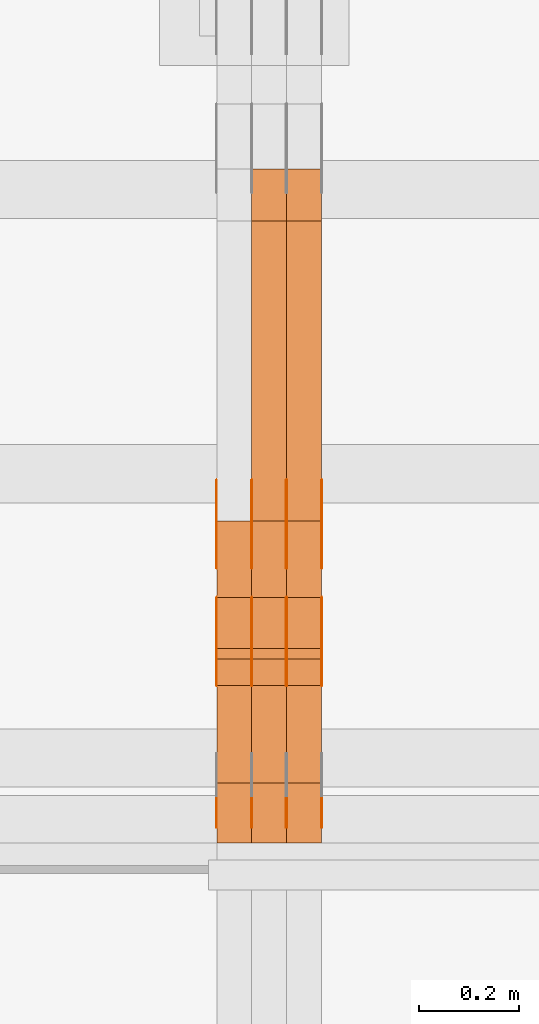
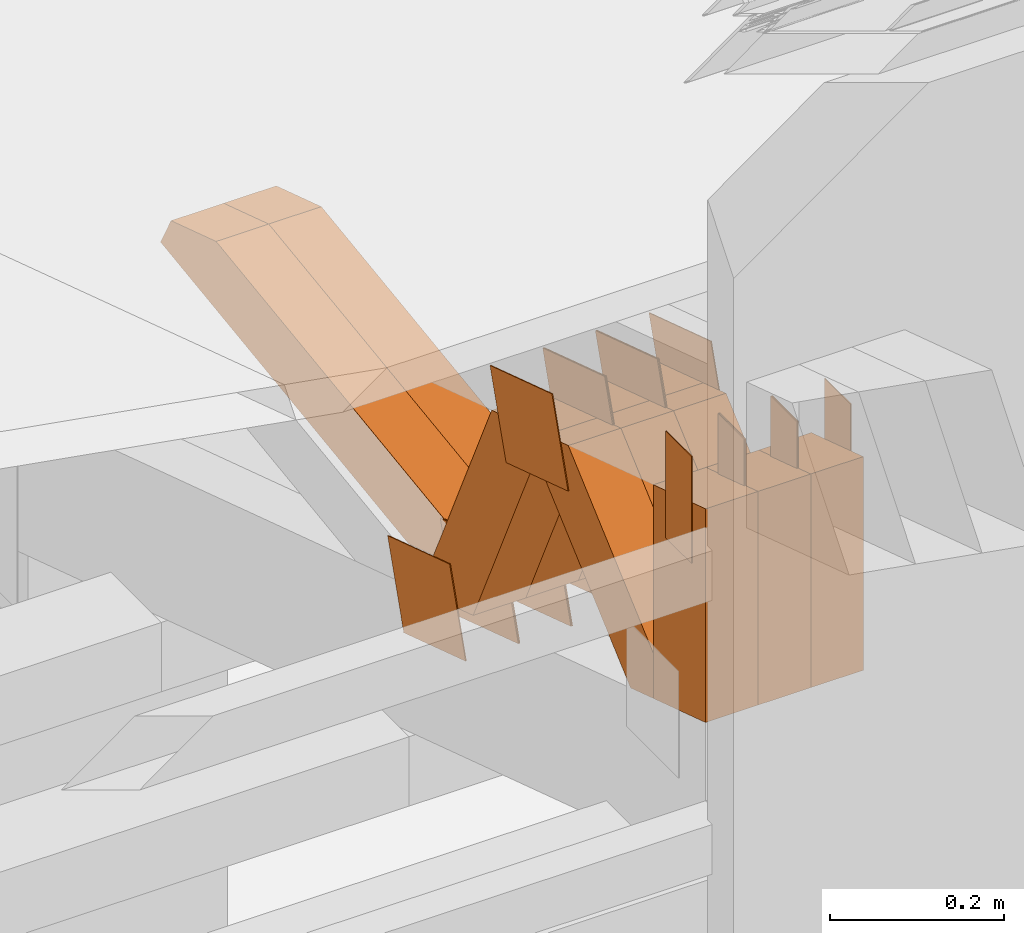
# One storey, part 102 of 385: 29 proxies.
"""IFC2X3 building model written with IfcOpenShell, lengths in millimetres."""

import ifcopenshell
import ifcopenshell.guid

model = None  # the IFC model being written
_history = None  # IfcOwnerHistory: only IFC2X3 demands one
_inside = {}  # id of a spatial element -> (the spatial element, [elements in it])
_under = {}  # id of a project, library or spatial element -> (it, [spatial elements below it])
_declared = {}  # id of a project -> (the project, [libraries it declares])
_typed = {}  # id of a type object -> (the type object, [elements of that type])
_made_of = {}  # id of a material, layer set ... -> (it, [elements and type objects made of it])


def new_model(schema):
    """Start an empty IFC model of exactly this schema.

    Asked for "IFC4X3", IfcOpenShell would pick the latest addendum, in which some entities
    have other attributes; the version numbers below select the first issue.
    IFC2X3 requires an IfcOwnerHistory on every rooted entity: one is made here for all.
    """
    global model, _history
    if schema == "IFC4X3":
        model = ifcopenshell.file(schema_version=(4, 3, 0, 0))
    else:
        model = ifcopenshell.file(schema=schema)
    _inside.clear()
    _under.clear()
    _declared.clear()
    _typed.clear()
    _made_of.clear()
    _history = None
    if model.schema == "IFC2X3":
        org = make("IfcOrganization", Name="unknown")
        user = make(
            "IfcPersonAndOrganization",
            ThePerson=make("IfcPerson", FamilyName="unknown"),
            TheOrganization=org,
        )
        app = make(
            "IfcApplication",
            ApplicationDeveloper=org,
            Version="unknown",
            ApplicationFullName="unknown",
            ApplicationIdentifier="unknown",
        )
        _history = make(
            "IfcOwnerHistory",
            OwningUser=user,
            OwningApplication=app,
            ChangeAction="ADDED",
            CreationDate=0,
        )
    return model


def make(cls, **values):
    """One entity of the class cls with the attributes given. An attribute that is None is left unset."""
    return model.create_entity(
        cls, **{name: value for name, value in values.items() if value is not None}
    )


def entity(cls, *values):
    """Any entity or typed value of the class cls, its attributes in the order of the schema. None: left unset."""
    e = model.create_entity(cls)
    for i, value in enumerate(values):
        if value is not None:
            e[i] = value
    return e


def rooted(cls, **values):
    """An entity with a GlobalId (a new one), such as an element, a storey or a relation."""
    return make(cls, GlobalId=ifcopenshell.guid.new(), OwnerHistory=_history, **values)


def si_unit(unit_type, name, prefix=None):
    """IfcSIUnit, for example si_unit("LENGTHUNIT", "METRE", prefix="MILLI")."""
    return make("IfcSIUnit", UnitType=unit_type, Prefix=prefix, Name=name)


def converted_unit(unit_type, name, factor, base, dimensions=None, offset=None):
    """IfcConversionBasedUnit, such as the inch: factor (a typed value) times the base unit."""
    return make(
        "IfcConversionBasedUnit"
        if offset is None
        else "IfcConversionBasedUnitWithOffset",
        ConversionOffset=offset,
        Dimensions=None
        if dimensions is None
        else entity("IfcDimensionalExponents", *dimensions),
        UnitType=unit_type,
        Name=name,
        ConversionFactor=make(
            "IfcMeasureWithUnit", ValueComponent=factor, UnitComponent=base
        ),
    )


def derived_unit(unit_type, elements):
    """IfcDerivedUnit: a product of units, each with its exponent."""
    return make(
        "IfcDerivedUnit",
        Elements=[
            make("IfcDerivedUnitElement", Unit=unit, Exponent=power)
            for unit, power in elements
        ],
        UnitType=unit_type,
    )


def assignment(units):
    """IfcUnitAssignment: the units of a project."""
    return None if units is None else make("IfcUnitAssignment", Units=units)


def point(xyz):
    """IfcCartesianPoint."""
    return None if xyz is None else make("IfcCartesianPoint", Coordinates=xyz)


def direction(xyz):
    """IfcDirection."""
    return None if xyz is None else make("IfcDirection", DirectionRatios=xyz)


def frame(location, z_axis=None, x_axis=None):
    """IfcAxis2Placement3D, a coordinate frame: its origin and axes. An axis left out is left unset."""
    return make(
        "IfcAxis2Placement3D",
        Location=point(location),
        Axis=direction(z_axis),
        RefDirection=direction(x_axis),
    )


def frame_2d(location, x_axis=None):
    """IfcAxis2Placement2D, a coordinate frame in the plane: its origin and x axis."""
    return make(
        "IfcAxis2Placement2D", Location=point(location), RefDirection=direction(x_axis)
    )


def origin():
    """The frame at (0, 0, 0) with its axes left unset."""
    return frame((0.0, 0.0, 0.0))


def origin_2d_with_axis():
    """The frame at (0, 0) in the plane with the x axis (1, 0) written out."""
    return frame_2d((0.0, 0.0), x_axis=(1.0, 0.0))


def place(relative_to, where):
    """IfcLocalPlacement: puts the frame where relative to a parent placement (None: the world)."""
    return make(
        "IfcLocalPlacement", PlacementRelTo=relative_to, RelativePlacement=where
    )


def context(
    kind, dimensions, precision=None, world=None, true_north=None, identifier=None
):
    """IfcGeometricRepresentationContext, for example the 3D "Model" context."""
    return make(
        "IfcGeometricRepresentationContext",
        ContextIdentifier=identifier,
        ContextType=kind,
        CoordinateSpaceDimension=dimensions,
        Precision=precision,
        WorldCoordinateSystem=world,
        TrueNorth=true_north,
    )


def subcontext(parent, identifier, kind, view, scale=None):
    """IfcGeometricRepresentationSubContext, for example "Body" below "Model"."""
    return make(
        "IfcGeometricRepresentationSubContext",
        ContextIdentifier=identifier,
        ContextType=kind,
        ParentContext=parent,
        TargetScale=scale,
        TargetView=view,
    )


def project(units=None, contexts=None):
    """IfcProject with its units and contexts."""
    return rooted(
        "IfcProject",
        Name="project",
        RepresentationContexts=contexts,
        UnitsInContext=assignment(units),
    )


def spatial(cls, under=None, at=None, **own):
    """A site, building, storey or space (cls), placed at a placement, below another one or the project."""
    s = rooted(cls, ObjectPlacement=at, **own)
    if under is not None:
        _under.setdefault(under.id(), (under, []))[1].append(s)
    return s


def polyline(points):
    """IfcPolyline through the points."""
    return make("IfcPolyline", Points=[point(p) for p in points])


def profile(cls, at=None, kind="AREA", **sizes):
    """A parametric profile (cls). Its sizes go by their IFC names, for example OverallWidth=200.0."""
    return make(cls, ProfileType=kind, Position=at, **sizes)


def rectangle(**sizes):
    """IfcRectangleProfileDef."""
    return profile("IfcRectangleProfileDef", **sizes)


def outline(outer, holes=None, kind="AREA"):
    """IfcArbitraryClosedProfileDef: a profile drawn as a closed curve; with holes, ...WithVoids."""
    if holes is None:
        return make("IfcArbitraryClosedProfileDef", ProfileType=kind, OuterCurve=outer)
    return make(
        "IfcArbitraryProfileDefWithVoids",
        ProfileType=kind,
        OuterCurve=outer,
        InnerCurves=holes,
    )


def extrude(swept, where, along, depth):
    """IfcExtrudedAreaSolid: the profile swept, set in the frame where, extruded along a direction by depth."""
    return make(
        "IfcExtrudedAreaSolid",
        SweptArea=swept,
        Position=where,
        ExtrudedDirection=direction(along),
        Depth=depth,
    )


def shape(context_of_items, identifier, shape_type, items):
    """IfcShapeRepresentation: the items that make up one representation, for example the "Body"."""
    return make(
        "IfcShapeRepresentation",
        ContextOfItems=context_of_items,
        RepresentationIdentifier=identifier,
        RepresentationType=shape_type,
        Items=items,
    )


def source(mapping_origin, context_of_items, identifier, shape_type, items):
    """IfcRepresentationMap: a shape defined once, which mapped items show again and again."""
    return make(
        "IfcRepresentationMap",
        MappingOrigin=mapping_origin,
        MappedRepresentation=shape(context_of_items, identifier, shape_type, items),
    )


def transform(
    local_origin,
    x_axis=None,
    y_axis=None,
    z_axis=None,
    scale=None,
    scale2=None,
    scale3=None,
    uniform=True,
):
    """IfcCartesianTransformationOperator3D, or its non-uniform kind. x_axis, y_axis, z_axis: its Axis1, 2, 3."""
    if uniform:
        return make(
            "IfcCartesianTransformationOperator3D",
            Axis1=direction(x_axis),
            Axis2=direction(y_axis),
            LocalOrigin=point(local_origin),
            Scale=scale,
            Axis3=direction(z_axis),
        )
    return make(
        "IfcCartesianTransformationOperator3DnonUniform",
        Axis1=direction(x_axis),
        Axis2=direction(y_axis),
        LocalOrigin=point(local_origin),
        Scale=scale,
        Axis3=direction(z_axis),
        Scale2=scale2,
        Scale3=scale3,
    )


def mapped(mapping_source, mapping_target):
    """IfcMappedItem: shows the shape of a source again, moved by a transform."""
    return make(
        "IfcMappedItem", MappingSource=mapping_source, MappingTarget=mapping_target
    )


def material(Name=None, Category=None):
    """IfcMaterial."""
    return make("IfcMaterial", Name=Name, Category=Category)


def made_of(thing, what):
    """Note that an element or type object is made of a material, layer set ...; save() writes the relation."""
    if what is not None:
        _made_of.setdefault(what.id(), (what, []))[1].append(thing)
    return thing


def type_object(cls, material=None, **own):
    """A type object (cls), such as IfcWallType, which elements share."""
    return made_of(rooted(cls, **own), material)


def type_shapes(of_type, sources):
    """Give a type object the sources (RepresentationMaps) that its elements show as mapped items."""
    of_type.RepresentationMaps = sources


def element(
    cls,
    number,
    at=None,
    inside=None,
    cuts=None,
    type_object=None,
    material=None,
    context=None,
    identifier="Body",
    shape_type=None,
    held_by="IfcProductDefinitionShape",
    body=None,
    shapes=None,
    **own,
):
    """One element of the class cls, such as IfcWall. Its Tag is "e" and its number.

    at: its placement. inside: the storey or other place that contains it. cuts: it is an
    opening in that element (IfcRelVoidsElement). A single representation is given by context,
    identifier, shape_type and body (its items); several are given by shapes. held_by: the class
    of the entity that holds the representations. save() writes the other relations.
    """
    e = rooted(cls, Tag="e%d" % number, ObjectPlacement=at, **own)
    if body is not None:
        shapes = [shape(context, identifier, shape_type, body)]
    if shapes is not None:
        e.Representation = make(held_by, Representations=shapes)
    if inside is not None:
        _inside.setdefault(inside.id(), (inside, []))[1].append(e)
    if cuts is not None:
        rooted(
            "IfcRelVoidsElement", RelatingBuildingElement=cuts, RelatedOpeningElement=e
        )
    if type_object is not None:
        _typed.setdefault(type_object.id(), (type_object, []))[1].append(e)
    return made_of(e, material)


def aggregate(whole, parts):
    """IfcRelAggregates: a whole, such as a stair, and the parts it consists of."""
    return rooted("IfcRelAggregates", RelatingObject=whole, RelatedObjects=parts)


def save(model, path):
    """Write the relations noted so far, then the file.

    IfcRelAggregates (storeys below a building ...), IfcRelContainedInSpatialStructure (elements
    in a storey), IfcRelDefinesByType, IfcRelAssociatesMaterial and IfcRelDeclares: one each for
    every whole, place, type object, material and project.
    """
    for whole, parts in _under.values():
        aggregate(whole, parts)
    for where, things in _inside.values():
        rooted(
            "IfcRelContainedInSpatialStructure",
            RelatedElements=things,
            RelatingStructure=where,
        )
    for kind, things in _typed.values():
        rooted("IfcRelDefinesByType", RelatedObjects=things, RelatingType=kind)
    for what, things in _made_of.values():
        rooted("IfcRelAssociatesMaterial", RelatedObjects=things, RelatingMaterial=what)
    for by, libraries in _declared.values():
        rooted("IfcRelDeclares", RelatingContext=by, RelatedDefinitions=libraries)
    model.write(path)


model = new_model("IFC2X3")

# Units and contexts
model_context = context("Model", 3, precision=0.01, world=origin(), true_north=direction((6.12303176911189e-17, 1.0)))
body_context = subcontext(model_context, "Body", "Model", "MODEL_VIEW")
ifc_project = project(units=[si_unit("LENGTHUNIT", "METRE", prefix="MILLI"), si_unit("AREAUNIT", "SQUARE_METRE"), si_unit("VOLUMEUNIT", "CUBIC_METRE"), converted_unit("PLANEANGLEUNIT", "DEGREE", entity("IfcRatioMeasure", 0.0174532925199433), si_unit("PLANEANGLEUNIT", "RADIAN"), dimensions=[0, 0, 0, 0, 0, 0, 0]), si_unit("MASSUNIT", "GRAM", prefix="KILO"), derived_unit("MASSDENSITYUNIT", [(si_unit("MASSUNIT", "GRAM", prefix="KILO"), 1), (si_unit("LENGTHUNIT", "METRE"), -3)]), si_unit("TIMEUNIT", "SECOND"), si_unit("FREQUENCYUNIT", "HERTZ"), si_unit("THERMODYNAMICTEMPERATUREUNIT", "DEGREE_CELSIUS"), derived_unit("THERMALTRANSMITTANCEUNIT", [(si_unit("MASSUNIT", "GRAM", prefix="KILO"), 1), (si_unit("THERMODYNAMICTEMPERATUREUNIT", "KELVIN"), -1), (si_unit("TIMEUNIT", "SECOND"), -3)]), derived_unit("VOLUMETRICFLOWRATEUNIT", [(si_unit("LENGTHUNIT", "METRE"), 3), (si_unit("TIMEUNIT", "SECOND"), -1)]), si_unit("ELECTRICCURRENTUNIT", "AMPERE"), si_unit("ELECTRICVOLTAGEUNIT", "VOLT"), si_unit("POWERUNIT", "WATT"), si_unit("FORCEUNIT", "NEWTON", prefix="KILO"), si_unit("ILLUMINANCEUNIT", "LUX"), si_unit("LUMINOUSFLUXUNIT", "LUMEN"), si_unit("LUMINOUSINTENSITYUNIT", "CANDELA"), derived_unit("USERDEFINED", [(si_unit("MASSUNIT", "GRAM", prefix="KILO"), -1), (si_unit("LENGTHUNIT", "METRE"), -2), (si_unit("TIMEUNIT", "SECOND"), 3), (si_unit("LUMINOUSFLUXUNIT", "LUMEN"), 1)]), derived_unit("LINEARVELOCITYUNIT", [(si_unit("LENGTHUNIT", "METRE"), 1), (si_unit("TIMEUNIT", "SECOND"), -1)]), si_unit("PRESSUREUNIT", "PASCAL"), derived_unit("USERDEFINED", [(si_unit("LENGTHUNIT", "METRE"), -2), (si_unit("MASSUNIT", "GRAM", prefix="KILO"), 1), (si_unit("TIMEUNIT", "SECOND"), -2)])], contexts=[model_context])

# Site, building, storey
site_placement = place(None, origin())
site = spatial("IfcSite", under=ifc_project, at=site_placement, CompositionType="ELEMENT")
building_placement = place(site_placement, origin())
building = spatial("IfcBuilding", under=site, at=building_placement, CompositionType="ELEMENT")
storey_placement = place(building_placement, origin())
storey = spatial("IfcBuildingStorey", under=building, at=storey_placement, Name="Default", CompositionType="ELEMENT", Elevation=0.0)

# Proxies
ifc_material_1 = material(Name="IfcSurfaceStyle #170604")
building_element_proxy_type_1 = type_object("IfcBuildingElementProxyType", PredefinedType="NOTDEFINED", material=ifc_material_1)
shared_shape_1 = source(origin(), body_context, "Body", "SweptSolid", [
    extrude(outline(polyline([(-74.9998605591118, -59.9999264677601), (74.9998754286171, -59.9999264677601), (74.9998605591118, 59.9999264677602), (-74.9998754286171, 59.9999264677602), (-74.9998605591118, -59.9999264677601)])), frame((74.9998754286171, 60.0000503992849, 0.0), z_axis=(0.0, 0.0, 1.0), x_axis=(-1.0, 0.0, 0.0)), (0.0, 0.0, 1.0), 1.3),
])
type_shapes(building_element_proxy_type_1, [shared_shape_1])
proxy_1_placement = place(building_placement, frame((12386.3, 16352.8320303235, 3323.23212676408), z_axis=(-1.0, 0.0, 0.0), x_axis=(0.0, -0.951056516295124, 0.309016994375039)))
element("IfcBuildingElementProxy", 1, at=proxy_1_placement, inside=storey, type_object=building_element_proxy_type_1, material=ifc_material_1, context=body_context, shape_type="MappedRepresentation", body=[
    mapped(shared_shape_1, transform((0.0, 0.0, 0.0), scale=1.0)),
])
ifc_material_2 = material(Name="IfcSurfaceStyle #170547")
building_element_proxy_type_2 = type_object("IfcBuildingElementProxyType", PredefinedType="NOTDEFINED", material=ifc_material_2)
shared_shape_2 = source(origin(), body_context, "Body", "SweptSolid", [
    extrude(outline(polyline([(-74.9998605591118, -59.9999264677601), (74.9998754286171, -59.9999264677601), (74.9998605591118, 59.9999264677602), (-74.9998754286171, 59.9999264677602), (-74.9998605591118, -59.9999264677601)])), frame((74.9998754286171, 60.0000503992849, 0.0), z_axis=(0.0, 0.0, 1.0), x_axis=(-1.0, 0.0, 0.0)), (0.0, 0.0, 1.0), 1.3),
])
type_shapes(building_element_proxy_type_2, [shared_shape_2])
proxy_2_placement = place(building_placement, frame((12315.0, 16352.8320303235, 3323.23212676408), z_axis=(-1.0, 0.0, 0.0), x_axis=(0.0, -0.951056516295124, 0.309016994375039)))
element("IfcBuildingElementProxy", 2, at=proxy_2_placement, inside=storey, type_object=building_element_proxy_type_2, material=ifc_material_2, context=body_context, shape_type="MappedRepresentation", body=[
    mapped(shared_shape_2, transform((0.0, 0.0, 0.0), scale=1.0)),
])
ifc_material_3 = material(Name="IfcSurfaceStyle #170490")
building_element_proxy_type_3 = type_object("IfcBuildingElementProxyType", PredefinedType="NOTDEFINED", material=ifc_material_3)
shared_shape_3 = source(origin(), body_context, "Body", "SweptSolid", [
    extrude(outline(polyline([(-74.9998605591118, -59.9999264677601), (74.9998754286171, -59.9999264677601), (74.9998605591118, 59.9999264677602), (-74.9998754286171, 59.9999264677602), (-74.9998605591118, -59.9999264677601)])), frame((74.9998754286171, 60.0000503992849, 0.0), z_axis=(0.0, 0.0, 1.0), x_axis=(-1.0, 0.0, 0.0)), (0.0, 0.0, 1.0), 1.3),
])
type_shapes(building_element_proxy_type_3, [shared_shape_3])
proxy_3_placement = place(building_placement, frame((12316.3, 16352.8320303235, 3323.23212676408), z_axis=(-1.0, 0.0, 0.0), x_axis=(0.0, -0.951056516295124, 0.309016994375039)))
element("IfcBuildingElementProxy", 3, at=proxy_3_placement, inside=storey, type_object=building_element_proxy_type_3, material=ifc_material_3, context=body_context, shape_type="MappedRepresentation", body=[
    mapped(shared_shape_3, transform((0.0, 0.0, 0.0), scale=1.0)),
])
ifc_material_4 = material(Name="IfcSurfaceStyle #170433")
building_element_proxy_type_4 = type_object("IfcBuildingElementProxyType", PredefinedType="NOTDEFINED", material=ifc_material_4)
shared_shape_4 = source(origin(), body_context, "Body", "SweptSolid", [
    extrude(outline(polyline([(-74.9998605591118, -59.9999264677601), (74.9998754286171, -59.9999264677601), (74.9998605591118, 59.9999264677602), (-74.9998754286171, 59.9999264677602), (-74.9998605591118, -59.9999264677601)])), frame((74.9998754286171, 60.0000503992849, 0.0), z_axis=(0.0, 0.0, 1.0), x_axis=(-1.0, 0.0, 0.0)), (0.0, 0.0, 1.0), 1.29999999999999),
])
type_shapes(building_element_proxy_type_4, [shared_shape_4])
proxy_4_placement = place(building_placement, frame((12245.0, 16352.8320303235, 3323.23212676408), z_axis=(-1.0, 0.0, 0.0), x_axis=(0.0, -0.951056516295124, 0.309016994375039)))
element("IfcBuildingElementProxy", 4, at=proxy_4_placement, inside=storey, type_object=building_element_proxy_type_4, material=ifc_material_4, context=body_context, shape_type="MappedRepresentation", body=[
    mapped(shared_shape_4, transform((0.0, 0.0, 0.0), scale=1.0)),
])
ifc_material_5 = material(Name="IfcSurfaceStyle #170376")
building_element_proxy_type_5 = type_object("IfcBuildingElementProxyType", PredefinedType="NOTDEFINED", material=ifc_material_5)
shared_shape_5 = source(origin(), body_context, "Body", "SweptSolid", [
    extrude(outline(polyline([(-74.9998605591118, -59.9999264677601), (74.9998754286171, -59.9999264677601), (74.9998605591118, 59.9999264677602), (-74.9998754286171, 59.9999264677602), (-74.9998605591118, -59.9999264677601)])), frame((74.9998754286171, 60.0000503992849, 0.0), z_axis=(0.0, 0.0, 1.0), x_axis=(-1.0, 0.0, 0.0)), (0.0, 0.0, 1.0), 1.29999999999999),
])
type_shapes(building_element_proxy_type_5, [shared_shape_5])
proxy_5_placement = place(building_placement, frame((12246.3, 16352.8320303235, 3323.23212676408), z_axis=(-1.0, 0.0, 0.0), x_axis=(0.0, -0.951056516295124, 0.309016994375039)))
element("IfcBuildingElementProxy", 5, at=proxy_5_placement, inside=storey, type_object=building_element_proxy_type_5, material=ifc_material_5, context=body_context, shape_type="MappedRepresentation", body=[
    mapped(shared_shape_5, transform((0.0, 0.0, 0.0), scale=1.0)),
])
ifc_material_6 = material(Name="IfcSurfaceStyle #170319")
building_element_proxy_type_6 = type_object("IfcBuildingElementProxyType", PredefinedType="NOTDEFINED", material=ifc_material_6)
shared_shape_6 = source(origin(), body_context, "Body", "SweptSolid", [
    extrude(outline(polyline([(-74.9998605591118, -59.9999264677601), (74.9998754286171, -59.9999264677601), (74.9998605591118, 59.9999264677602), (-74.9998754286171, 59.9999264677602), (-74.9998605591118, -59.9999264677601)])), frame((74.9998754286171, 60.0000503992849, 0.0), z_axis=(0.0, 0.0, 1.0), x_axis=(-1.0, 0.0, 0.0)), (0.0, 0.0, 1.0), 1.29999999999999),
])
type_shapes(building_element_proxy_type_6, [shared_shape_6])
proxy_6_placement = place(building_placement, frame((12175.0, 16352.8320303235, 3323.23212676408), z_axis=(-1.0, 0.0, 0.0), x_axis=(0.0, -0.951056516295124, 0.309016994375039)))
element("IfcBuildingElementProxy", 6, at=proxy_6_placement, inside=storey, type_object=building_element_proxy_type_6, material=ifc_material_6, context=body_context, shape_type="MappedRepresentation", body=[
    mapped(shared_shape_6, transform((0.0, 0.0, 0.0), scale=1.0)),
])
ifc_material_7 = material(Name="IfcSurfaceStyle #166158")
building_element_proxy_type_7 = type_object("IfcBuildingElementProxyType", PredefinedType="NOTDEFINED", material=ifc_material_7)
shared_shape_7 = source(origin(), body_context, "Body", "SweptSolid", [
    extrude(outline(polyline([(-75.0003249421702, -60.0000773549573), (75.0003398116874, -60.0000773549573), (75.0003249421711, 60.0000773549573), (-75.0003398116883, 60.0000773549573), (-75.0003249421702, -60.0000773549573)])), frame((75.0003398116874, 60.0000773549573, 0.0), z_axis=(0.0, 0.0, 1.0), x_axis=(-1.0, 0.0, 0.0)), (0.0, 0.0, 1.0), 1.3),
])
type_shapes(building_element_proxy_type_7, [shared_shape_7])
proxy_7_placement = place(building_placement, frame((12386.3, 16117.0849050545, 3705.49074668796), z_axis=(-1.0, 0.0, 0.0), x_axis=(0.0, -0.951056516295154, 0.309016994374948)))
element("IfcBuildingElementProxy", 7, at=proxy_7_placement, inside=storey, type_object=building_element_proxy_type_7, material=ifc_material_7, context=body_context, shape_type="MappedRepresentation", body=[
    mapped(shared_shape_7, transform((0.0, 0.0, 0.0), scale=1.0)),
])
ifc_material_8 = material(Name="IfcSurfaceStyle #166101")
building_element_proxy_type_8 = type_object("IfcBuildingElementProxyType", PredefinedType="NOTDEFINED", material=ifc_material_8)
shared_shape_8 = source(origin(), body_context, "Body", "SweptSolid", [
    extrude(outline(polyline([(-75.0003249421702, -60.0000773549573), (75.0003398116874, -60.0000773549573), (75.0003249421711, 60.0000773549573), (-75.0003398116883, 60.0000773549573), (-75.0003249421702, -60.0000773549573)])), frame((75.0003398116874, 60.0000773549573, 0.0), z_axis=(0.0, 0.0, 1.0), x_axis=(-1.0, 0.0, 0.0)), (0.0, 0.0, 1.0), 1.3),
])
type_shapes(building_element_proxy_type_8, [shared_shape_8])
proxy_8_placement = place(building_placement, frame((12315.0, 16117.0849050545, 3705.49074668796), z_axis=(-1.0, 0.0, 0.0), x_axis=(0.0, -0.951056516295154, 0.309016994374948)))
element("IfcBuildingElementProxy", 8, at=proxy_8_placement, inside=storey, type_object=building_element_proxy_type_8, material=ifc_material_8, context=body_context, shape_type="MappedRepresentation", body=[
    mapped(shared_shape_8, transform((0.0, 0.0, 0.0), scale=1.0)),
])
ifc_material_9 = material(Name="IfcSurfaceStyle #166044")
building_element_proxy_type_9 = type_object("IfcBuildingElementProxyType", PredefinedType="NOTDEFINED", material=ifc_material_9)
shared_shape_9 = source(origin(), body_context, "Body", "SweptSolid", [
    extrude(outline(polyline([(-75.0003249421702, -60.0000773549573), (75.0003398116874, -60.0000773549573), (75.0003249421711, 60.0000773549573), (-75.0003398116883, 60.0000773549573), (-75.0003249421702, -60.0000773549573)])), frame((75.0003398116874, 60.0000773549573, 0.0), z_axis=(0.0, 0.0, 1.0), x_axis=(-1.0, 0.0, 0.0)), (0.0, 0.0, 1.0), 1.3),
])
type_shapes(building_element_proxy_type_9, [shared_shape_9])
proxy_9_placement = place(building_placement, frame((12316.3, 16117.0849050545, 3705.49074668796), z_axis=(-1.0, 0.0, 0.0), x_axis=(0.0, -0.951056516295154, 0.309016994374948)))
element("IfcBuildingElementProxy", 9, at=proxy_9_placement, inside=storey, type_object=building_element_proxy_type_9, material=ifc_material_9, context=body_context, shape_type="MappedRepresentation", body=[
    mapped(shared_shape_9, transform((0.0, 0.0, 0.0), scale=1.0)),
])
ifc_material_10 = material(Name="IfcSurfaceStyle #165987")
building_element_proxy_type_10 = type_object("IfcBuildingElementProxyType", PredefinedType="NOTDEFINED", material=ifc_material_10)
shared_shape_10 = source(origin(), body_context, "Body", "SweptSolid", [
    extrude(outline(polyline([(-75.0003249421702, -60.0000773549573), (75.0003398116874, -60.0000773549573), (75.0003249421711, 60.0000773549573), (-75.0003398116883, 60.0000773549573), (-75.0003249421702, -60.0000773549573)])), frame((75.0003398116874, 60.0000773549573, 0.0), z_axis=(0.0, 0.0, 1.0), x_axis=(-1.0, 0.0, 0.0)), (0.0, 0.0, 1.0), 1.29999999999999),
])
type_shapes(building_element_proxy_type_10, [shared_shape_10])
proxy_10_placement = place(building_placement, frame((12245.0, 16117.0849050545, 3705.49074668796), z_axis=(-1.0, 0.0, 0.0), x_axis=(0.0, -0.951056516295154, 0.309016994374948)))
element("IfcBuildingElementProxy", 10, at=proxy_10_placement, inside=storey, type_object=building_element_proxy_type_10, material=ifc_material_10, context=body_context, shape_type="MappedRepresentation", body=[
    mapped(shared_shape_10, transform((0.0, 0.0, 0.0), scale=1.0)),
])
ifc_material_11 = material(Name="IfcSurfaceStyle #165930")
building_element_proxy_type_11 = type_object("IfcBuildingElementProxyType", PredefinedType="NOTDEFINED", material=ifc_material_11)
shared_shape_11 = source(origin(), body_context, "Body", "SweptSolid", [
    extrude(outline(polyline([(-75.0003249421702, -60.0000773549573), (75.0003398116874, -60.0000773549573), (75.0003249421711, 60.0000773549573), (-75.0003398116883, 60.0000773549573), (-75.0003249421702, -60.0000773549573)])), frame((75.0003398116874, 60.0000773549573, 0.0), z_axis=(0.0, 0.0, 1.0), x_axis=(-1.0, 0.0, 0.0)), (0.0, 0.0, 1.0), 1.29999999999999),
])
type_shapes(building_element_proxy_type_11, [shared_shape_11])
proxy_11_placement = place(building_placement, frame((12246.3, 16117.0849050545, 3705.49074668796), z_axis=(-1.0, 0.0, 0.0), x_axis=(0.0, -0.951056516295154, 0.309016994374948)))
element("IfcBuildingElementProxy", 11, at=proxy_11_placement, inside=storey, type_object=building_element_proxy_type_11, material=ifc_material_11, context=body_context, shape_type="MappedRepresentation", body=[
    mapped(shared_shape_11, transform((0.0, 0.0, 0.0), scale=1.0)),
])
ifc_material_12 = material(Name="IfcSurfaceStyle #165873")
building_element_proxy_type_12 = type_object("IfcBuildingElementProxyType", PredefinedType="NOTDEFINED", material=ifc_material_12)
shared_shape_12 = source(origin(), body_context, "Body", "SweptSolid", [
    extrude(outline(polyline([(-75.0003249421702, -60.0000773549573), (75.0003398116874, -60.0000773549573), (75.0003249421711, 60.0000773549573), (-75.0003398116883, 60.0000773549573), (-75.0003249421702, -60.0000773549573)])), frame((75.0003398116874, 60.0000773549573, 0.0), z_axis=(0.0, 0.0, 1.0), x_axis=(-1.0, 0.0, 0.0)), (0.0, 0.0, 1.0), 1.29999999999999),
])
type_shapes(building_element_proxy_type_12, [shared_shape_12])
proxy_12_placement = place(building_placement, frame((12175.0, 16117.0849050545, 3705.49074668796), z_axis=(-1.0, 0.0, 0.0), x_axis=(0.0, -0.951056516295154, 0.309016994374948)))
element("IfcBuildingElementProxy", 12, at=proxy_12_placement, inside=storey, type_object=building_element_proxy_type_12, material=ifc_material_12, context=body_context, shape_type="MappedRepresentation", body=[
    mapped(shared_shape_12, transform((0.0, 0.0, 0.0), scale=1.0)),
])
ifc_material_13 = material(Name="IfcSurfaceStyle #165474")
building_element_proxy_type_13 = type_object("IfcBuildingElementProxyType", PredefinedType="NOTDEFINED", material=ifc_material_13)
shared_shape_13 = source(origin(), body_context, "Body", "SweptSolid", [
    extrude(rectangle(XDim=150.0, YDim=60.0, at=origin_2d_with_axis()), frame((75.0000705696311, 30.0, 0.0), z_axis=(0.0, 0.0, 1.0), x_axis=(-1.0, 0.0, 0.0)), (0.0, 0.0, 1.0), 1.3),
])
type_shapes(building_element_proxy_type_13, [shared_shape_13])
proxy_13_placement = place(building_placement, frame((12386.3, 15750.0, 3972.59919166338), z_axis=(-1.0, 0.0, 0.0), x_axis=(0.0, 0.0, -1.0)))
element("IfcBuildingElementProxy", 13, at=proxy_13_placement, inside=storey, type_object=building_element_proxy_type_13, material=ifc_material_13, context=body_context, shape_type="MappedRepresentation", body=[
    mapped(shared_shape_13, transform((0.0, 0.0, 0.0), scale=1.0)),
])
ifc_material_14 = material(Name="IfcSurfaceStyle #165417")
building_element_proxy_type_14 = type_object("IfcBuildingElementProxyType", PredefinedType="NOTDEFINED", material=ifc_material_14)
shared_shape_14 = source(origin(), body_context, "Body", "SweptSolid", [
    extrude(rectangle(XDim=150.0, YDim=60.0, at=origin_2d_with_axis()), frame((75.0000705696311, 30.0, 0.0), z_axis=(0.0, 0.0, 1.0), x_axis=(-1.0, 0.0, 0.0)), (0.0, 0.0, 1.0), 1.3),
])
type_shapes(building_element_proxy_type_14, [shared_shape_14])
proxy_14_placement = place(building_placement, frame((12315.0, 15750.0, 3972.59919166338), z_axis=(-1.0, 0.0, 0.0), x_axis=(0.0, 0.0, -1.0)))
element("IfcBuildingElementProxy", 14, at=proxy_14_placement, inside=storey, type_object=building_element_proxy_type_14, material=ifc_material_14, context=body_context, shape_type="MappedRepresentation", body=[
    mapped(shared_shape_14, transform((0.0, 0.0, 0.0), scale=1.0)),
])
ifc_material_15 = material(Name="IfcSurfaceStyle #165360")
building_element_proxy_type_15 = type_object("IfcBuildingElementProxyType", PredefinedType="NOTDEFINED", material=ifc_material_15)
shared_shape_15 = source(origin(), body_context, "Body", "SweptSolid", [
    extrude(rectangle(XDim=150.0, YDim=60.0, at=origin_2d_with_axis()), frame((75.0000705696311, 30.0, 0.0), z_axis=(0.0, 0.0, 1.0), x_axis=(-1.0, 0.0, 0.0)), (0.0, 0.0, 1.0), 1.3),
])
type_shapes(building_element_proxy_type_15, [shared_shape_15])
proxy_15_placement = place(building_placement, frame((12316.3, 15750.0, 3972.59919166338), z_axis=(-1.0, 0.0, 0.0), x_axis=(0.0, 0.0, -1.0)))
element("IfcBuildingElementProxy", 15, at=proxy_15_placement, inside=storey, type_object=building_element_proxy_type_15, material=ifc_material_15, context=body_context, shape_type="MappedRepresentation", body=[
    mapped(shared_shape_15, transform((0.0, 0.0, 0.0), scale=1.0)),
])
ifc_material_16 = material(Name="IfcSurfaceStyle #165303")
building_element_proxy_type_16 = type_object("IfcBuildingElementProxyType", PredefinedType="NOTDEFINED", material=ifc_material_16)
shared_shape_16 = source(origin(), body_context, "Body", "SweptSolid", [
    extrude(rectangle(XDim=150.0, YDim=60.0, at=origin_2d_with_axis()), frame((75.0000705696311, 30.0, 0.0), z_axis=(0.0, 0.0, 1.0), x_axis=(-1.0, 0.0, 0.0)), (0.0, 0.0, 1.0), 1.29999999999999),
])
type_shapes(building_element_proxy_type_16, [shared_shape_16])
proxy_16_placement = place(building_placement, frame((12245.0, 15750.0, 3972.59919166338), z_axis=(-1.0, 0.0, 0.0), x_axis=(0.0, 0.0, -1.0)))
element("IfcBuildingElementProxy", 16, at=proxy_16_placement, inside=storey, type_object=building_element_proxy_type_16, material=ifc_material_16, context=body_context, shape_type="MappedRepresentation", body=[
    mapped(shared_shape_16, transform((0.0, 0.0, 0.0), scale=1.0)),
])
ifc_material_17 = material(Name="IfcSurfaceStyle #165246")
building_element_proxy_type_17 = type_object("IfcBuildingElementProxyType", PredefinedType="NOTDEFINED", material=ifc_material_17)
shared_shape_17 = source(origin(), body_context, "Body", "SweptSolid", [
    extrude(rectangle(XDim=150.0, YDim=60.0, at=origin_2d_with_axis()), frame((75.0000705696311, 30.0, 0.0), z_axis=(0.0, 0.0, 1.0), x_axis=(-1.0, 0.0, 0.0)), (0.0, 0.0, 1.0), 1.29999999999999),
])
type_shapes(building_element_proxy_type_17, [shared_shape_17])
proxy_17_placement = place(building_placement, frame((12246.3, 15750.0, 3972.59919166338), z_axis=(-1.0, 0.0, 0.0), x_axis=(0.0, 0.0, -1.0)))
element("IfcBuildingElementProxy", 17, at=proxy_17_placement, inside=storey, type_object=building_element_proxy_type_17, material=ifc_material_17, context=body_context, shape_type="MappedRepresentation", body=[
    mapped(shared_shape_17, transform((0.0, 0.0, 0.0), scale=1.0)),
])
ifc_material_18 = material(Name="IfcSurfaceStyle #165189")
building_element_proxy_type_18 = type_object("IfcBuildingElementProxyType", PredefinedType="NOTDEFINED", material=ifc_material_18)
shared_shape_18 = source(origin(), body_context, "Body", "SweptSolid", [
    extrude(rectangle(XDim=150.0, YDim=60.0, at=origin_2d_with_axis()), frame((75.0000705696311, 30.0, 0.0), z_axis=(0.0, 0.0, 1.0), x_axis=(-1.0, 0.0, 0.0)), (0.0, 0.0, 1.0), 1.29999999999999),
])
type_shapes(building_element_proxy_type_18, [shared_shape_18])
proxy_18_placement = place(building_placement, frame((12175.0, 15750.0, 3972.59919166338), z_axis=(-1.0, 0.0, 0.0), x_axis=(0.0, 0.0, -1.0)))
element("IfcBuildingElementProxy", 18, at=proxy_18_placement, inside=storey, type_object=building_element_proxy_type_18, material=ifc_material_18, context=body_context, shape_type="MappedRepresentation", body=[
    mapped(shared_shape_18, transform((0.0, 0.0, 0.0), scale=1.0)),
])
ifc_material_19 = material(Name="IfcSurfaceStyle #156105")
building_element_proxy_type_19 = type_object("IfcBuildingElementProxyType", Name="T1-W50 156103", PredefinedType="NOTDEFINED", material=ifc_material_19)
shared_shape_19 = source(origin(), body_context, "Body", "SweptSolid", [
    extrude(outline(polyline([(-128.56619634284, -47.4999385885712), (133.151257249084, -47.4999385885712), (161.172800006526, -0.000129729183733609), (147.291467726413, 47.500068317755), (-142.513973767368, 47.500068317755), (-170.535354871815, -0.000129729183754689), (-128.56619634284, -47.4999385885712)])), frame((161.17310141218, 47.5001898716564, 0.0), z_axis=(0.0, 0.0, 1.0), x_axis=(-1.0, 0.0, 0.0)), (0.0, 0.0, 1.0), 70.0),
])
type_shapes(building_element_proxy_type_19, [shared_shape_19])
proxy_19_placement = place(building_placement, frame((12385.0, 16060.0297689714, 3761.73994820667), z_axis=(-1.0, 0.0, 0.0), x_axis=(0.0, -0.749388407538668, -0.662130662820156)))
element("IfcBuildingElementProxy", 19, at=proxy_19_placement, inside=storey, type_object=building_element_proxy_type_19, material=ifc_material_19, Name="T1-W50", context=body_context, shape_type="MappedRepresentation", body=[
    mapped(shared_shape_19, transform((0.0, 0.0, 0.0), scale=1.0)),
])
ifc_material_20 = material(Name="IfcSurfaceStyle #156030")
building_element_proxy_type_20 = type_object("IfcBuildingElementProxyType", Name="T1-W50 156028", PredefinedType="NOTDEFINED", material=ifc_material_20)
shared_shape_20 = source(origin(), body_context, "Body", "SweptSolid", [
    extrude(outline(polyline([(-128.56619634284, -47.4999385885712), (133.151257249084, -47.4999385885712), (161.172800006526, -0.000129729183733609), (147.291467726413, 47.500068317755), (-142.513973767368, 47.500068317755), (-170.535354871815, -0.000129729183754689), (-128.56619634284, -47.4999385885712)])), frame((161.17310141218, 47.5001898716564, 0.0), z_axis=(0.0, 0.0, 1.0), x_axis=(-1.0, 0.0, 0.0)), (0.0, 0.0, 1.0), 70.0),
])
type_shapes(building_element_proxy_type_20, [shared_shape_20])
proxy_20_placement = place(building_placement, frame((12315.0, 16060.0297689714, 3761.73994820667), z_axis=(-1.0, 0.0, 0.0), x_axis=(0.0, -0.749388407538668, -0.662130662820156)))
element("IfcBuildingElementProxy", 20, at=proxy_20_placement, inside=storey, type_object=building_element_proxy_type_20, material=ifc_material_20, Name="T1-W50", context=body_context, shape_type="MappedRepresentation", body=[
    mapped(shared_shape_20, transform((0.0, 0.0, 0.0), scale=1.0)),
])
ifc_material_21 = material(Name="IfcSurfaceStyle #155955")
building_element_proxy_type_21 = type_object("IfcBuildingElementProxyType", Name="T1-W50 155953", PredefinedType="NOTDEFINED", material=ifc_material_21)
shared_shape_21 = source(origin(), body_context, "Body", "SweptSolid", [
    extrude(outline(polyline([(-128.56619634284, -47.4999385885712), (133.151257249084, -47.4999385885712), (161.172800006526, -0.000129729183733609), (147.291467726413, 47.500068317755), (-142.513973767368, 47.500068317755), (-170.535354871815, -0.000129729183754689), (-128.56619634284, -47.4999385885712)])), frame((161.17310141218, 47.5001898716564, 0.0), z_axis=(0.0, 0.0, 1.0), x_axis=(-1.0, 0.0, 0.0)), (0.0, 0.0, 1.0), 70.0),
])
type_shapes(building_element_proxy_type_21, [shared_shape_21])
proxy_21_placement = place(building_placement, frame((12245.0, 16060.0297689714, 3761.73994820667), z_axis=(-1.0, 0.0, 0.0), x_axis=(0.0, -0.749388407538668, -0.662130662820156)))
element("IfcBuildingElementProxy", 21, at=proxy_21_placement, inside=storey, type_object=building_element_proxy_type_21, material=ifc_material_21, Name="T1-W50", context=body_context, shape_type="MappedRepresentation", body=[
    mapped(shared_shape_21, transform((0.0, 0.0, 0.0), scale=1.0)),
])
ifc_material_22 = material(Name="IfcSurfaceStyle #155709")
building_element_proxy_type_22 = type_object("IfcBuildingElementProxyType", Name="T1-W2 155707", PredefinedType="NOTDEFINED", material=ifc_material_22)
shared_shape_22 = source(origin(), body_context, "Body", "SweptSolid", [
    extrude(outline(polyline([(-130.705993652344, -60.0), (169.696350097656, -60.0), (130.706115722656, 60.0), (-169.696472167969, 60.0), (-130.705993652344, -60.0)])), frame((169.696429629256, 60.0, 0.0), z_axis=(0.0, 0.0, 1.0), x_axis=(-1.0, 0.0, 0.0)), (0.0, 0.0, 1.0), 70.0),
])
type_shapes(building_element_proxy_type_22, [shared_shape_22])
proxy_22_placement = place(building_placement, frame((12385.0, 15660.0, 3577.70158062465), z_axis=(-1.0, 0.0, 0.0), x_axis=(0.0, 0.0, 1.0)))
element("IfcBuildingElementProxy", 22, at=proxy_22_placement, inside=storey, type_object=building_element_proxy_type_22, material=ifc_material_22, Name="T1-W2", context=body_context, shape_type="MappedRepresentation", body=[
    mapped(shared_shape_22, transform((0.0, 0.0, 0.0), scale=1.0)),
])
ifc_material_23 = material(Name="IfcSurfaceStyle #155652")
building_element_proxy_type_23 = type_object("IfcBuildingElementProxyType", Name="T1-W2 155650", PredefinedType="NOTDEFINED", material=ifc_material_23)
shared_shape_23 = source(origin(), body_context, "Body", "SweptSolid", [
    extrude(outline(polyline([(-130.705993652344, -60.0), (169.696350097656, -60.0), (130.706115722656, 60.0), (-169.696472167969, 60.0), (-130.705993652344, -60.0)])), frame((169.696429629256, 60.0, 0.0), z_axis=(0.0, 0.0, 1.0), x_axis=(-1.0, 0.0, 0.0)), (0.0, 0.0, 1.0), 70.0),
])
type_shapes(building_element_proxy_type_23, [shared_shape_23])
proxy_23_placement = place(building_placement, frame((12315.0, 15660.0, 3577.70158062465), z_axis=(-1.0, 0.0, 0.0), x_axis=(0.0, 0.0, 1.0)))
element("IfcBuildingElementProxy", 23, at=proxy_23_placement, inside=storey, type_object=building_element_proxy_type_23, material=ifc_material_23, Name="T1-W2", context=body_context, shape_type="MappedRepresentation", body=[
    mapped(shared_shape_23, transform((0.0, 0.0, 0.0), scale=1.0)),
])
ifc_material_24 = material(Name="IfcSurfaceStyle #155595")
building_element_proxy_type_24 = type_object("IfcBuildingElementProxyType", Name="T1-W2 155593", PredefinedType="NOTDEFINED", material=ifc_material_24)
shared_shape_24 = source(origin(), body_context, "Body", "SweptSolid", [
    extrude(outline(polyline([(-130.705993652344, -60.0), (169.696350097656, -60.0), (130.706115722656, 60.0), (-169.696472167969, 60.0), (-130.705993652344, -60.0)])), frame((169.696429629256, 60.0, 0.0), z_axis=(0.0, 0.0, 1.0), x_axis=(-1.0, 0.0, 0.0)), (0.0, 0.0, 1.0), 70.0),
])
type_shapes(building_element_proxy_type_24, [shared_shape_24])
proxy_24_placement = place(building_placement, frame((12245.0, 15660.0, 3577.70158062465), z_axis=(-1.0, 0.0, 0.0), x_axis=(0.0, 0.0, 1.0)))
element("IfcBuildingElementProxy", 24, at=proxy_24_placement, inside=storey, type_object=building_element_proxy_type_24, material=ifc_material_24, Name="T1-W2", context=body_context, shape_type="MappedRepresentation", body=[
    mapped(shared_shape_24, transform((0.0, 0.0, 0.0), scale=1.0)),
])
ifc_material_25 = material(Name="IfcSurfaceStyle #155538")
building_element_proxy_type_25 = type_object("IfcBuildingElementProxyType", Name="T1-W44 155536", PredefinedType="NOTDEFINED", material=ifc_material_25)
shared_shape_25 = source(origin(), body_context, "Body", "SweptSolid", [
    extrude(outline(polyline([(-184.551057772692, -47.4997984945814), (177.527112951531, -47.4997984945814), (162.630077773546, -0.000452497529500495), (118.068221667048, 47.5000247433462), (-273.674354619433, 47.5000247433462), (-184.551057772692, -47.4997984945814)])), frame((177.527112951531, 47.5002721629815, 0.0), z_axis=(0.0, 0.0, 1.0), x_axis=(-1.0, 0.0, 0.0)), (0.0, 0.0, 1.0), 70.0),
])
type_shapes(building_element_proxy_type_25, [shared_shape_25])
proxy_25_placement = place(building_placement, frame((12385.0, 16220.4899216004, 3388.98238154171), z_axis=(-1.0, 0.0, 0.0), x_axis=(0.0, -0.425335045192995, 0.905035965766374)))
element("IfcBuildingElementProxy", 25, at=proxy_25_placement, inside=storey, type_object=building_element_proxy_type_25, material=ifc_material_25, Name="T1-W44", context=body_context, shape_type="MappedRepresentation", body=[
    mapped(shared_shape_25, transform((0.0, 0.0, 0.0), scale=1.0)),
])
ifc_material_26 = material(Name="IfcSurfaceStyle #155472")
building_element_proxy_type_26 = type_object("IfcBuildingElementProxyType", Name="T1-W44 155470", PredefinedType="NOTDEFINED", material=ifc_material_26)
shared_shape_26 = source(origin(), body_context, "Body", "SweptSolid", [
    extrude(outline(polyline([(-184.551057772692, -47.4997984945814), (177.527112951531, -47.4997984945814), (162.630077773546, -0.000452497529500495), (118.068221667048, 47.5000247433462), (-273.674354619433, 47.5000247433462), (-184.551057772692, -47.4997984945814)])), frame((177.527112951531, 47.5002721629815, 0.0), z_axis=(0.0, 0.0, 1.0), x_axis=(-1.0, 0.0, 0.0)), (0.0, 0.0, 1.0), 70.0),
])
type_shapes(building_element_proxy_type_26, [shared_shape_26])
proxy_26_placement = place(building_placement, frame((12315.0, 16220.4899216004, 3388.98238154171), z_axis=(-1.0, 0.0, 0.0), x_axis=(0.0, -0.425335045192995, 0.905035965766374)))
element("IfcBuildingElementProxy", 26, at=proxy_26_placement, inside=storey, type_object=building_element_proxy_type_26, material=ifc_material_26, Name="T1-W44", context=body_context, shape_type="MappedRepresentation", body=[
    mapped(shared_shape_26, transform((0.0, 0.0, 0.0), scale=1.0)),
])
ifc_material_27 = material(Name="IfcSurfaceStyle #155406")
building_element_proxy_type_27 = type_object("IfcBuildingElementProxyType", Name="T1-W44 155404", PredefinedType="NOTDEFINED", material=ifc_material_27)
shared_shape_27 = source(origin(), body_context, "Body", "SweptSolid", [
    extrude(outline(polyline([(-184.551057772692, -47.4997984945814), (177.527112951531, -47.4997984945814), (162.630077773546, -0.000452497529500495), (118.068221667048, 47.5000247433462), (-273.674354619433, 47.5000247433462), (-184.551057772692, -47.4997984945814)])), frame((177.527112951531, 47.5002721629815, 0.0), z_axis=(0.0, 0.0, 1.0), x_axis=(-1.0, 0.0, 0.0)), (0.0, 0.0, 1.0), 70.0),
])
type_shapes(building_element_proxy_type_27, [shared_shape_27])
proxy_27_placement = place(building_placement, frame((12245.0, 16220.4899216004, 3388.98238154171), z_axis=(-1.0, 0.0, 0.0), x_axis=(0.0, -0.425335045192995, 0.905035965766374)))
element("IfcBuildingElementProxy", 27, at=proxy_27_placement, inside=storey, type_object=building_element_proxy_type_27, material=ifc_material_27, Name="T1-W44", context=body_context, shape_type="MappedRepresentation", body=[
    mapped(shared_shape_27, transform((0.0, 0.0, 0.0), scale=1.0)),
])
ifc_material_28 = material(Name="IfcSurfaceStyle #155142")
building_element_proxy_type_28 = type_object("IfcBuildingElementProxyType", Name="T1-W8 155140", PredefinedType="NOTDEFINED", material=ifc_material_28)
shared_shape_28 = source(origin(), body_context, "Body", "SweptSolid", [
    extrude(outline(polyline([(-476.725263324644, -47.5001051695965), (180.672765845439, -47.5001051695965), (279.11020091716, -1.03605560390907e-06), (296.793624402619, 47.5001056876243), (-279.851327840575, 47.5001056876243), (-476.725263324644, -47.5001051695965)])), frame((296.793624402619, 47.5001056876243, 0.0), z_axis=(0.0, 0.0, 1.0), x_axis=(-1.0, 0.0, 0.0)), (0.0, 0.0, 1.0), 70.0),
])
type_shapes(building_element_proxy_type_28, [shared_shape_28])
proxy_28_placement = place(building_placement, frame((12385.0, 17036.40625, 3432.97192382813), z_axis=(-1.0, 0.0, 0.0), x_axis=(0.0, -0.990844046556832, -0.135011389900564)))
element("IfcBuildingElementProxy", 28, at=proxy_28_placement, inside=storey, type_object=building_element_proxy_type_28, material=ifc_material_28, Name="T1-W8", context=body_context, shape_type="MappedRepresentation", body=[
    mapped(shared_shape_28, transform((0.0, 0.0, 0.0), scale=1.0)),
])
ifc_material_29 = material(Name="IfcSurfaceStyle #155076")
building_element_proxy_type_29 = type_object("IfcBuildingElementProxyType", Name="T1-W8 155074", PredefinedType="NOTDEFINED", material=ifc_material_29)
shared_shape_29 = source(origin(), body_context, "Body", "SweptSolid", [
    extrude(outline(polyline([(-476.725263324644, -47.5001051695965), (180.672765845439, -47.5001051695965), (279.11020091716, -1.03605560390907e-06), (296.793624402619, 47.5001056876243), (-279.851327840575, 47.5001056876243), (-476.725263324644, -47.5001051695965)])), frame((296.793624402619, 47.5001056876243, 0.0), z_axis=(0.0, 0.0, 1.0), x_axis=(-1.0, 0.0, 0.0)), (0.0, 0.0, 1.0), 70.0),
])
type_shapes(building_element_proxy_type_29, [shared_shape_29])
proxy_29_placement = place(building_placement, frame((12315.0, 17036.40625, 3432.97192382813), z_axis=(-1.0, 0.0, 0.0), x_axis=(0.0, -0.990844046556832, -0.135011389900564)))
element("IfcBuildingElementProxy", 29, at=proxy_29_placement, inside=storey, type_object=building_element_proxy_type_29, material=ifc_material_29, Name="T1-W8", context=body_context, shape_type="MappedRepresentation", body=[
    mapped(shared_shape_29, transform((0.0, 0.0, 0.0), scale=1.0)),
])

save(model, "model.ifc")
